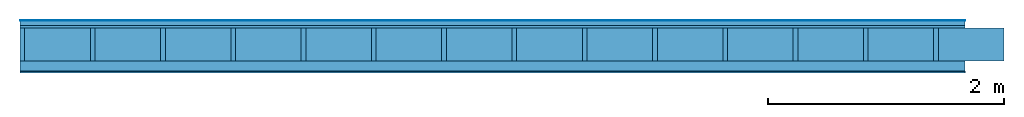
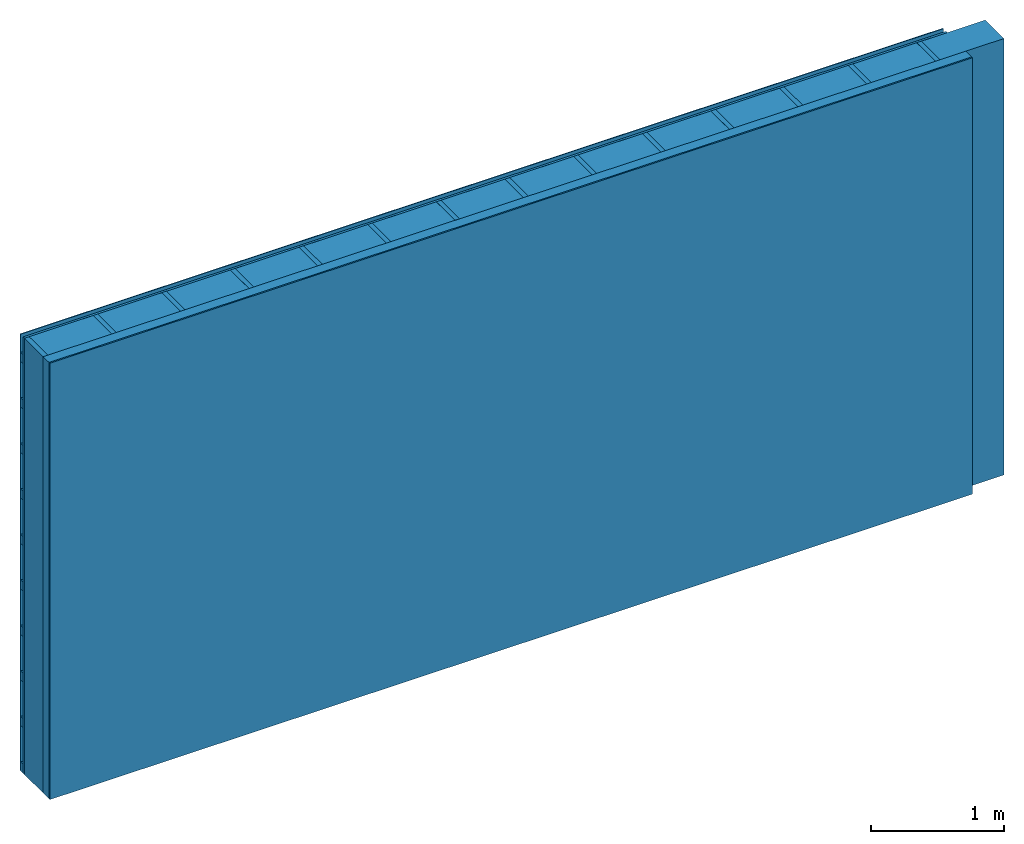
# One storey: 4 plates, 3 members, 1 element without a shape of its own.
"""IFC4 building model written with IfcOpenShell, lengths in metres."""

import ifcopenshell
import ifcopenshell.guid

model = None  # the IFC model being written
_history = None  # IfcOwnerHistory: only IFC2X3 demands one
_inside = {}  # id of a spatial element -> (the spatial element, [elements in it])
_under = {}  # id of a project, library or spatial element -> (it, [spatial elements below it])
_declared = {}  # id of a project -> (the project, [libraries it declares])
_typed = {}  # id of a type object -> (the type object, [elements of that type])
_made_of = {}  # id of a material, layer set ... -> (it, [elements and type objects made of it])


def new_model(schema):
    """Start an empty IFC model of exactly this schema.

    Asked for "IFC4X3", IfcOpenShell would pick the latest addendum, in which some entities
    have other attributes; the version numbers below select the first issue.
    IFC2X3 requires an IfcOwnerHistory on every rooted entity: one is made here for all.
    """
    global model, _history
    if schema == "IFC4X3":
        model = ifcopenshell.file(schema_version=(4, 3, 0, 0))
    else:
        model = ifcopenshell.file(schema=schema)
    _inside.clear()
    _under.clear()
    _declared.clear()
    _typed.clear()
    _made_of.clear()
    _history = None
    if model.schema == "IFC2X3":
        org = make("IfcOrganization", Name="unknown")
        user = make(
            "IfcPersonAndOrganization",
            ThePerson=make("IfcPerson", FamilyName="unknown"),
            TheOrganization=org,
        )
        app = make(
            "IfcApplication",
            ApplicationDeveloper=org,
            Version="unknown",
            ApplicationFullName="unknown",
            ApplicationIdentifier="unknown",
        )
        _history = make(
            "IfcOwnerHistory",
            OwningUser=user,
            OwningApplication=app,
            ChangeAction="ADDED",
            CreationDate=0,
        )
    return model


def make(cls, **values):
    """One entity of the class cls with the attributes given. An attribute that is None is left unset."""
    return model.create_entity(
        cls, **{name: value for name, value in values.items() if value is not None}
    )


def rooted(cls, **values):
    """An entity with a GlobalId (a new one), such as an element, a storey or a relation."""
    return make(cls, GlobalId=ifcopenshell.guid.new(), OwnerHistory=_history, **values)


def si_unit(unit_type, name, prefix=None):
    """IfcSIUnit, for example si_unit("LENGTHUNIT", "METRE", prefix="MILLI")."""
    return make("IfcSIUnit", UnitType=unit_type, Prefix=prefix, Name=name)


def derived_unit(unit_type, elements):
    """IfcDerivedUnit: a product of units, each with its exponent."""
    return make(
        "IfcDerivedUnit",
        Elements=[
            make("IfcDerivedUnitElement", Unit=unit, Exponent=power)
            for unit, power in elements
        ],
        UnitType=unit_type,
    )


def assignment(units):
    """IfcUnitAssignment: the units of a project."""
    return None if units is None else make("IfcUnitAssignment", Units=units)


def point(xyz):
    """IfcCartesianPoint."""
    return None if xyz is None else make("IfcCartesianPoint", Coordinates=xyz)


def direction(xyz):
    """IfcDirection."""
    return None if xyz is None else make("IfcDirection", DirectionRatios=xyz)


def frame(location, z_axis=None, x_axis=None):
    """IfcAxis2Placement3D, a coordinate frame: its origin and axes. An axis left out is left unset."""
    return make(
        "IfcAxis2Placement3D",
        Location=point(location),
        Axis=direction(z_axis),
        RefDirection=direction(x_axis),
    )


def frame_2d(location, x_axis=None):
    """IfcAxis2Placement2D, a coordinate frame in the plane: its origin and x axis."""
    return make(
        "IfcAxis2Placement2D", Location=point(location), RefDirection=direction(x_axis)
    )


def origin():
    """The frame at (0, 0, 0) with its axes left unset."""
    return frame((0.0, 0.0, 0.0))


def origin_with_axes():
    """The frame at (0, 0, 0) with the z axis (0, 0, 1) and the x axis (1, 0, 0) written out."""
    return frame((0.0, 0.0, 0.0), z_axis=(0.0, 0.0, 1.0), x_axis=(1.0, 0.0, 0.0))


def place(relative_to, where):
    """IfcLocalPlacement: puts the frame where relative to a parent placement (None: the world)."""
    return make(
        "IfcLocalPlacement", PlacementRelTo=relative_to, RelativePlacement=where
    )


def context(
    kind, dimensions, precision=None, world=None, true_north=None, identifier=None
):
    """IfcGeometricRepresentationContext, for example the 3D "Model" context."""
    return make(
        "IfcGeometricRepresentationContext",
        ContextIdentifier=identifier,
        ContextType=kind,
        CoordinateSpaceDimension=dimensions,
        Precision=precision,
        WorldCoordinateSystem=world,
        TrueNorth=true_north,
    )


def project(units=None, contexts=None):
    """IfcProject with its units and contexts."""
    return rooted(
        "IfcProject",
        Name="project",
        RepresentationContexts=contexts,
        UnitsInContext=assignment(units),
    )


def spatial(cls, under=None, at=None, **own):
    """A site, building, storey or space (cls), placed at a placement, below another one or the project."""
    s = rooted(cls, ObjectPlacement=at, **own)
    if under is not None:
        _under.setdefault(under.id(), (under, []))[1].append(s)
    return s


def profile(cls, at=None, kind="AREA", **sizes):
    """A parametric profile (cls). Its sizes go by their IFC names, for example OverallWidth=200.0."""
    return make(cls, ProfileType=kind, Position=at, **sizes)


def rectangle(**sizes):
    """IfcRectangleProfileDef."""
    return profile("IfcRectangleProfileDef", **sizes)


def extrude(swept, where, along, depth):
    """IfcExtrudedAreaSolid: the profile swept, set in the frame where, extruded along a direction by depth."""
    return make(
        "IfcExtrudedAreaSolid",
        SweptArea=swept,
        Position=where,
        ExtrudedDirection=direction(along),
        Depth=depth,
    )


def shape(context_of_items, identifier, shape_type, items):
    """IfcShapeRepresentation: the items that make up one representation, for example the "Body"."""
    return make(
        "IfcShapeRepresentation",
        ContextOfItems=context_of_items,
        RepresentationIdentifier=identifier,
        RepresentationType=shape_type,
        Items=items,
    )


def material(Name=None, Category=None):
    """IfcMaterial."""
    return make("IfcMaterial", Name=Name, Category=Category)


def layer(
    of_material, thickness, ventilated=None, Name=None, Category=None, Priority=None
):
    """IfcMaterialLayer: one layer of a wall or slab, of a material (None: an air gap)."""
    return make(
        "IfcMaterialLayer",
        Material=of_material,
        LayerThickness=thickness,
        IsVentilated=ventilated,
        Name=Name,
        Category=Category,
        Priority=Priority,
    )


def layer_set(layers, Name=None):
    """IfcMaterialLayerSet."""
    return make("IfcMaterialLayerSet", MaterialLayers=layers, LayerSetName=Name)


def made_of(thing, what):
    """Note that an element or type object is made of a material, layer set ...; save() writes the relation."""
    if what is not None:
        _made_of.setdefault(what.id(), (what, []))[1].append(thing)
    return thing


def type_object(cls, material=None, **own):
    """A type object (cls), such as IfcWallType, which elements share."""
    return made_of(rooted(cls, **own), material)


def element(
    cls,
    number,
    at=None,
    inside=None,
    cuts=None,
    type_object=None,
    material=None,
    context=None,
    identifier="Body",
    shape_type=None,
    held_by="IfcProductDefinitionShape",
    body=None,
    shapes=None,
    **own,
):
    """One element of the class cls, such as IfcWall. Its Tag is "e" and its number.

    at: its placement. inside: the storey or other place that contains it. cuts: it is an
    opening in that element (IfcRelVoidsElement). A single representation is given by context,
    identifier, shape_type and body (its items); several are given by shapes. held_by: the class
    of the entity that holds the representations. save() writes the other relations.
    """
    e = rooted(cls, Tag="e%d" % number, ObjectPlacement=at, **own)
    if body is not None:
        shapes = [shape(context, identifier, shape_type, body)]
    if shapes is not None:
        e.Representation = make(held_by, Representations=shapes)
    if inside is not None:
        _inside.setdefault(inside.id(), (inside, []))[1].append(e)
    if cuts is not None:
        rooted(
            "IfcRelVoidsElement", RelatingBuildingElement=cuts, RelatedOpeningElement=e
        )
    if type_object is not None:
        _typed.setdefault(type_object.id(), (type_object, []))[1].append(e)
    return made_of(e, material)


def aggregate(whole, parts):
    """IfcRelAggregates: a whole, such as a stair, and the parts it consists of."""
    return rooted("IfcRelAggregates", RelatingObject=whole, RelatedObjects=parts)


def save(model, path):
    """Write the relations noted so far, then the file.

    IfcRelAggregates (storeys below a building ...), IfcRelContainedInSpatialStructure (elements
    in a storey), IfcRelDefinesByType, IfcRelAssociatesMaterial and IfcRelDeclares: one each for
    every whole, place, type object, material and project.
    """
    for whole, parts in _under.values():
        aggregate(whole, parts)
    for where, things in _inside.values():
        rooted(
            "IfcRelContainedInSpatialStructure",
            RelatedElements=things,
            RelatingStructure=where,
        )
    for kind, things in _typed.values():
        rooted("IfcRelDefinesByType", RelatedObjects=things, RelatingType=kind)
    for what, things in _made_of.values():
        rooted("IfcRelAssociatesMaterial", RelatedObjects=things, RelatingMaterial=what)
    for by, libraries in _declared.values():
        rooted("IfcRelDeclares", RelatingContext=by, RelatedDefinitions=libraries)
    model.write(path)


model = new_model("IFC4")

# Units and contexts
plan_context = context("Plan", 3, precision=1e-05, world=origin(), true_north=direction((0.0, 1.0)))
model_context = context("Model", 3, precision=1e-05, world=origin(), true_north=direction((0.0, 1.0)))
ifc_project = project(units=[si_unit("LENGTHUNIT", "METRE"), derived_unit("SOUNDPRESSUREUNIT", [(si_unit("PRESSUREUNIT", "PASCAL", prefix="MICRO"), 0)]), si_unit("ENERGYUNIT", "JOULE", prefix="MEGA"), si_unit("MASSUNIT", "GRAM", prefix="KILO"), derived_unit("THERMALTRANSMITTANCEUNIT", [(si_unit("POWERUNIT", "WATT"), 1), (si_unit("AREAUNIT", "SQUARE_METRE"), -1), (si_unit("THERMODYNAMICTEMPERATUREUNIT", "KELVIN"), -1)]), derived_unit("AREADENSITYUNIT", [(si_unit("MASSUNIT", "GRAM", prefix="KILO"), 1), (si_unit("AREAUNIT", "SQUARE_METRE"), -1)]), derived_unit("USERDEFINED", [(si_unit("ENERGYUNIT", "JOULE", prefix="MEGA"), 1), (si_unit("AREAUNIT", "SQUARE_METRE"), -1)])], contexts=[plan_context, model_context])

# Site, building, storey
site = spatial("IfcSite", under=ifc_project)
building_placement = place(None, origin())
building = spatial("IfcBuilding", under=site, at=building_placement)
storey_placement = place(building_placement, origin())
storey = spatial("IfcBuildingStorey", under=building, at=storey_placement)

# Wall, members, plates
ifc_material_1 = material(Name="mineral, cement-based building board", Category="03.003")
ifc_layer_1 = layer(ifc_material_1, 0.008, Name="Cover 1st layer")
ifc_layer_2 = layer(None, 0.04, Name="Battens / profiles (ventilation)")
ifc_material_2 = material(Category="10.009")
ifc_layer_3 = layer(ifc_material_2, 0.02, Name="outside 1st layer")
ifc_material_3 = material(Name="of the art")
ifc_layer_4 = layer(ifc_material_3, 0.0, Name="Bond")
ifc_layer_5 = layer(None, 0.28, Name="Support")
ifc_layer_6 = layer(ifc_material_3, 0.0, Name="Bond")
ifc_material_4 = material(Name="Solid timber panel")
ifc_layer_7 = layer(ifc_material_4, 0.087, Name="1st layer")
ifc_material_5 = material(Name="Plasterboard type A", Category="03.008")
ifc_layer_8 = layer(ifc_material_5, 0.0125, Name="Covering 1st layer")
ifc_material_6 = material(Name="joints", Category="04.017")
ifc_layer_9 = layer(ifc_material_6, 0.0, Name="Surface")
ifc_layer_set = layer_set([ifc_layer_1, ifc_layer_2, ifc_layer_3, ifc_layer_4, ifc_layer_5, ifc_layer_6, ifc_layer_7, ifc_layer_8, ifc_layer_9])
wall_type = type_object("IfcWallType", Name="D0972", PredefinedType="NOTDEFINED", material=ifc_layer_set)
wall_placement = place(None, frame((0.0, 0.0, 0.0), z_axis=(0.0, -1.0, 0.0), x_axis=(1.0, 0.0, 0.0)))
wall = element("IfcWall", 1, at=wall_placement, inside=storey, type_object=wall_type, material=ifc_layer_set, Name="Wall #1")
ifc_material_7 = material()
member_1_placement = place(wall_placement, origin())
member_1 = element("IfcMember", 2, at=member_1_placement, material=ifc_material_7, Name="Battens / profiles (ventilation)", context=plan_context, shape_type="SweptSolid", body=[
    extrude(rectangle(XDim=0.08, YDim=0.04, at=frame_2d((0.04, 0.02), x_axis=(1.0, 0.0))), frame((0.0, 0.0, 0.008), z_axis=(1.0, 0.0, 0.0), x_axis=(0.0, 1.0, 0.0)), (0.0, 0.0, 1.0), 8.0),
    extrude(rectangle(XDim=0.08, YDim=0.04, at=frame_2d((0.04, 0.02), x_axis=(1.0, 0.0))), frame((0.0, 0.417, 0.008), z_axis=(1.0, 0.0, 0.0), x_axis=(0.0, 1.0, 0.0)), (0.0, 0.0, 1.0), 8.0),
    extrude(rectangle(XDim=0.08, YDim=0.04, at=frame_2d((0.04, 0.02), x_axis=(1.0, 0.0))), frame((0.0, 0.834, 0.008), z_axis=(1.0, 0.0, 0.0), x_axis=(0.0, 1.0, 0.0)), (0.0, 0.0, 1.0), 8.0),
    extrude(rectangle(XDim=0.08, YDim=0.04, at=frame_2d((0.04, 0.02), x_axis=(1.0, 0.0))), frame((0.0, 1.251, 0.008), z_axis=(1.0, 0.0, 0.0), x_axis=(0.0, 1.0, 0.0)), (0.0, 0.0, 1.0), 8.0),
    extrude(rectangle(XDim=0.08, YDim=0.04, at=frame_2d((0.04, 0.02), x_axis=(1.0, 0.0))), frame((0.0, 1.668, 0.008), z_axis=(1.0, 0.0, 0.0), x_axis=(0.0, 1.0, 0.0)), (0.0, 0.0, 1.0), 8.0),
    extrude(rectangle(XDim=0.08, YDim=0.04, at=frame_2d((0.04, 0.02), x_axis=(1.0, 0.0))), frame((0.0, 2.085, 0.008), z_axis=(1.0, 0.0, 0.0), x_axis=(0.0, 1.0, 0.0)), (0.0, 0.0, 1.0), 8.0),
    extrude(rectangle(XDim=0.08, YDim=0.04, at=frame_2d((0.04, 0.02), x_axis=(1.0, 0.0))), frame((0.0, 2.502, 0.008), z_axis=(1.0, 0.0, 0.0), x_axis=(0.0, 1.0, 0.0)), (0.0, 0.0, 1.0), 8.0),
    extrude(rectangle(XDim=0.08, YDim=0.04, at=frame_2d((0.04, 0.02), x_axis=(1.0, 0.0))), frame((0.0, 2.919, 0.008), z_axis=(1.0, 0.0, 0.0), x_axis=(0.0, 1.0, 0.0)), (0.0, 0.0, 1.0), 8.0),
    extrude(rectangle(XDim=0.08, YDim=0.04, at=frame_2d((0.04, 0.02), x_axis=(1.0, 0.0))), frame((0.0, 3.336, 0.008), z_axis=(1.0, 0.0, 0.0), x_axis=(0.0, 1.0, 0.0)), (0.0, 0.0, 1.0), 8.0),
    extrude(rectangle(XDim=0.08, YDim=0.04, at=frame_2d((0.04, 0.02), x_axis=(1.0, 0.0))), frame((0.0, 3.753, 0.008), z_axis=(1.0, 0.0, 0.0), x_axis=(0.0, 1.0, 0.0)), (0.0, 0.0, 1.0), 8.0),
])
ifc_material_8 = material()
member_2_placement = place(wall_placement, origin())
member_2 = element("IfcMember", 3, at=member_2_placement, material=ifc_material_8, Name="Support", context=plan_context, shape_type="SweptSolid", body=[
    extrude(rectangle(XDim=0.04, YDim=0.28, at=frame_2d((0.02, 0.14), x_axis=(1.0, 0.0))), frame((0.0, 4.0, 0.068), z_axis=(0.0, -1.0, 0.0), x_axis=(1.0, 0.0, 0.0)), (0.0, 0.0, 1.0), 4.0),
    extrude(rectangle(XDim=0.04, YDim=0.28, at=frame_2d((0.02, 0.14), x_axis=(1.0, 0.0))), frame((0.595, 4.0, 0.068), z_axis=(0.0, -1.0, 0.0), x_axis=(1.0, 0.0, 0.0)), (0.0, 0.0, 1.0), 4.0),
    extrude(rectangle(XDim=0.04, YDim=0.28, at=frame_2d((0.02, 0.14), x_axis=(1.0, 0.0))), frame((1.19, 4.0, 0.068), z_axis=(0.0, -1.0, 0.0), x_axis=(1.0, 0.0, 0.0)), (0.0, 0.0, 1.0), 4.0),
    extrude(rectangle(XDim=0.04, YDim=0.28, at=frame_2d((0.02, 0.14), x_axis=(1.0, 0.0))), frame((1.785, 4.0, 0.068), z_axis=(0.0, -1.0, 0.0), x_axis=(1.0, 0.0, 0.0)), (0.0, 0.0, 1.0), 4.0),
    extrude(rectangle(XDim=0.04, YDim=0.28, at=frame_2d((0.02, 0.14), x_axis=(1.0, 0.0))), frame((2.38, 4.0, 0.068), z_axis=(0.0, -1.0, 0.0), x_axis=(1.0, 0.0, 0.0)), (0.0, 0.0, 1.0), 4.0),
    extrude(rectangle(XDim=0.04, YDim=0.28, at=frame_2d((0.02, 0.14), x_axis=(1.0, 0.0))), frame((2.975, 4.0, 0.068), z_axis=(0.0, -1.0, 0.0), x_axis=(1.0, 0.0, 0.0)), (0.0, 0.0, 1.0), 4.0),
    extrude(rectangle(XDim=0.04, YDim=0.28, at=frame_2d((0.02, 0.14), x_axis=(1.0, 0.0))), frame((3.57, 4.0, 0.068), z_axis=(0.0, -1.0, 0.0), x_axis=(1.0, 0.0, 0.0)), (0.0, 0.0, 1.0), 4.0),
    extrude(rectangle(XDim=0.04, YDim=0.28, at=frame_2d((0.02, 0.14), x_axis=(1.0, 0.0))), frame((4.165, 4.0, 0.068), z_axis=(0.0, -1.0, 0.0), x_axis=(1.0, 0.0, 0.0)), (0.0, 0.0, 1.0), 4.0),
    extrude(rectangle(XDim=0.04, YDim=0.28, at=frame_2d((0.02, 0.14), x_axis=(1.0, 0.0))), frame((4.76, 4.0, 0.068), z_axis=(0.0, -1.0, 0.0), x_axis=(1.0, 0.0, 0.0)), (0.0, 0.0, 1.0), 4.0),
    extrude(rectangle(XDim=0.04, YDim=0.28, at=frame_2d((0.02, 0.14), x_axis=(1.0, 0.0))), frame((5.355, 4.0, 0.068), z_axis=(0.0, -1.0, 0.0), x_axis=(1.0, 0.0, 0.0)), (0.0, 0.0, 1.0), 4.0),
    extrude(rectangle(XDim=0.04, YDim=0.28, at=frame_2d((0.02, 0.14), x_axis=(1.0, 0.0))), frame((5.95, 4.0, 0.068), z_axis=(0.0, -1.0, 0.0), x_axis=(1.0, 0.0, 0.0)), (0.0, 0.0, 1.0), 4.0),
    extrude(rectangle(XDim=0.04, YDim=0.28, at=frame_2d((0.02, 0.14), x_axis=(1.0, 0.0))), frame((6.545, 4.0, 0.068), z_axis=(0.0, -1.0, 0.0), x_axis=(1.0, 0.0, 0.0)), (0.0, 0.0, 1.0), 4.0),
    extrude(rectangle(XDim=0.04, YDim=0.28, at=frame_2d((0.02, 0.14), x_axis=(1.0, 0.0))), frame((7.14, 4.0, 0.068), z_axis=(0.0, -1.0, 0.0), x_axis=(1.0, 0.0, 0.0)), (0.0, 0.0, 1.0), 4.0),
    extrude(rectangle(XDim=0.04, YDim=0.28, at=frame_2d((0.02, 0.14), x_axis=(1.0, 0.0))), frame((7.735, 4.0, 0.068), z_axis=(0.0, -1.0, 0.0), x_axis=(1.0, 0.0, 0.0)), (0.0, 0.0, 1.0), 4.0),
])
ifc_material_9 = material()
member_3_placement = place(wall_placement, origin())
member_3 = element("IfcMember", 4, at=member_3_placement, material=ifc_material_9, Name="Cavity", context=plan_context, shape_type="SweptSolid", body=[
    extrude(rectangle(XDim=0.555, YDim=0.28, at=frame_2d((0.2775, 0.14), x_axis=(1.0, 0.0))), frame((0.04, 4.0, 0.068), z_axis=(0.0, -1.0, 0.0), x_axis=(1.0, 0.0, 0.0)), (0.0, 0.0, 1.0), 4.0),
    extrude(rectangle(XDim=0.555, YDim=0.28, at=frame_2d((0.2775, 0.14), x_axis=(1.0, 0.0))), frame((0.635, 4.0, 0.068), z_axis=(0.0, -1.0, 0.0), x_axis=(1.0, 0.0, 0.0)), (0.0, 0.0, 1.0), 4.0),
    extrude(rectangle(XDim=0.555, YDim=0.28, at=frame_2d((0.2775, 0.14), x_axis=(1.0, 0.0))), frame((1.23, 4.0, 0.068), z_axis=(0.0, -1.0, 0.0), x_axis=(1.0, 0.0, 0.0)), (0.0, 0.0, 1.0), 4.0),
    extrude(rectangle(XDim=0.555, YDim=0.28, at=frame_2d((0.2775, 0.14), x_axis=(1.0, 0.0))), frame((1.825, 4.0, 0.068), z_axis=(0.0, -1.0, 0.0), x_axis=(1.0, 0.0, 0.0)), (0.0, 0.0, 1.0), 4.0),
    extrude(rectangle(XDim=0.555, YDim=0.28, at=frame_2d((0.2775, 0.14), x_axis=(1.0, 0.0))), frame((2.42, 4.0, 0.068), z_axis=(0.0, -1.0, 0.0), x_axis=(1.0, 0.0, 0.0)), (0.0, 0.0, 1.0), 4.0),
    extrude(rectangle(XDim=0.555, YDim=0.28, at=frame_2d((0.2775, 0.14), x_axis=(1.0, 0.0))), frame((3.015, 4.0, 0.068), z_axis=(0.0, -1.0, 0.0), x_axis=(1.0, 0.0, 0.0)), (0.0, 0.0, 1.0), 4.0),
    extrude(rectangle(XDim=0.555, YDim=0.28, at=frame_2d((0.2775, 0.14), x_axis=(1.0, 0.0))), frame((3.61, 4.0, 0.068), z_axis=(0.0, -1.0, 0.0), x_axis=(1.0, 0.0, 0.0)), (0.0, 0.0, 1.0), 4.0),
    extrude(rectangle(XDim=0.555, YDim=0.28, at=frame_2d((0.2775, 0.14), x_axis=(1.0, 0.0))), frame((4.205, 4.0, 0.068), z_axis=(0.0, -1.0, 0.0), x_axis=(1.0, 0.0, 0.0)), (0.0, 0.0, 1.0), 4.0),
    extrude(rectangle(XDim=0.555, YDim=0.28, at=frame_2d((0.2775, 0.14), x_axis=(1.0, 0.0))), frame((4.8, 4.0, 0.068), z_axis=(0.0, -1.0, 0.0), x_axis=(1.0, 0.0, 0.0)), (0.0, 0.0, 1.0), 4.0),
    extrude(rectangle(XDim=0.555, YDim=0.28, at=frame_2d((0.2775, 0.14), x_axis=(1.0, 0.0))), frame((5.395, 4.0, 0.068), z_axis=(0.0, -1.0, 0.0), x_axis=(1.0, 0.0, 0.0)), (0.0, 0.0, 1.0), 4.0),
    extrude(rectangle(XDim=0.555, YDim=0.28, at=frame_2d((0.2775, 0.14), x_axis=(1.0, 0.0))), frame((5.99, 4.0, 0.068), z_axis=(0.0, -1.0, 0.0), x_axis=(1.0, 0.0, 0.0)), (0.0, 0.0, 1.0), 4.0),
    extrude(rectangle(XDim=0.555, YDim=0.28, at=frame_2d((0.2775, 0.14), x_axis=(1.0, 0.0))), frame((6.585, 4.0, 0.068), z_axis=(0.0, -1.0, 0.0), x_axis=(1.0, 0.0, 0.0)), (0.0, 0.0, 1.0), 4.0),
    extrude(rectangle(XDim=0.555, YDim=0.28, at=frame_2d((0.2775, 0.14), x_axis=(1.0, 0.0))), frame((7.18, 4.0, 0.068), z_axis=(0.0, -1.0, 0.0), x_axis=(1.0, 0.0, 0.0)), (0.0, 0.0, 1.0), 4.0),
    extrude(rectangle(XDim=0.555, YDim=0.28, at=frame_2d((0.2775, 0.14), x_axis=(1.0, 0.0))), frame((7.775, 4.0, 0.068), z_axis=(0.0, -1.0, 0.0), x_axis=(1.0, 0.0, 0.0)), (0.0, 0.0, 1.0), 4.0),
])
plate_1_placement = place(wall_placement, origin())
plate_1 = element("IfcPlate", 5, at=plate_1_placement, material=ifc_material_1, Name="Cover 1st layer", context=plan_context, shape_type="SweptSolid", body=[
    extrude(rectangle(XDim=8.0, YDim=4.0, at=frame_2d((4.0, 2.0), x_axis=(1.0, 0.0))), origin_with_axes(), (0.0, 0.0, 1.0), 0.008),
])
plate_2_placement = place(wall_placement, origin())
plate_2 = element("IfcPlate", 6, at=plate_2_placement, material=ifc_material_2, Name="outside 1st layer", context=plan_context, shape_type="SweptSolid", body=[
    extrude(rectangle(XDim=8.0, YDim=4.0, at=frame_2d((4.0, 2.0), x_axis=(1.0, 0.0))), frame((0.0, 0.0, 0.048), z_axis=(0.0, 0.0, 1.0), x_axis=(1.0, 0.0, 0.0)), (0.0, 0.0, 1.0), 0.02),
])
plate_3_placement = place(wall_placement, origin())
plate_3 = element("IfcPlate", 7, at=plate_3_placement, material=ifc_material_4, Name="1st layer", context=plan_context, shape_type="SweptSolid", body=[
    extrude(rectangle(XDim=8.0, YDim=4.0, at=frame_2d((4.0, 2.0), x_axis=(1.0, 0.0))), frame((0.0, 0.0, 0.348), z_axis=(0.0, 0.0, 1.0), x_axis=(1.0, 0.0, 0.0)), (0.0, 0.0, 1.0), 0.087),
])
plate_4_placement = place(wall_placement, origin())
plate_4 = element("IfcPlate", 8, at=plate_4_placement, material=ifc_material_5, Name="Covering 1st layer", context=plan_context, shape_type="SweptSolid", body=[
    extrude(rectangle(XDim=8.0, YDim=4.0, at=frame_2d((4.0, 2.0), x_axis=(1.0, 0.0))), frame((0.0, 0.0, 0.435), z_axis=(0.0, 0.0, 1.0), x_axis=(1.0, 0.0, 0.0)), (0.0, 0.0, 1.0), 0.0125),
])
aggregate(wall, [plate_1, member_1, plate_2, member_2, member_3, plate_3, plate_4])

save(model, "model.ifc")
